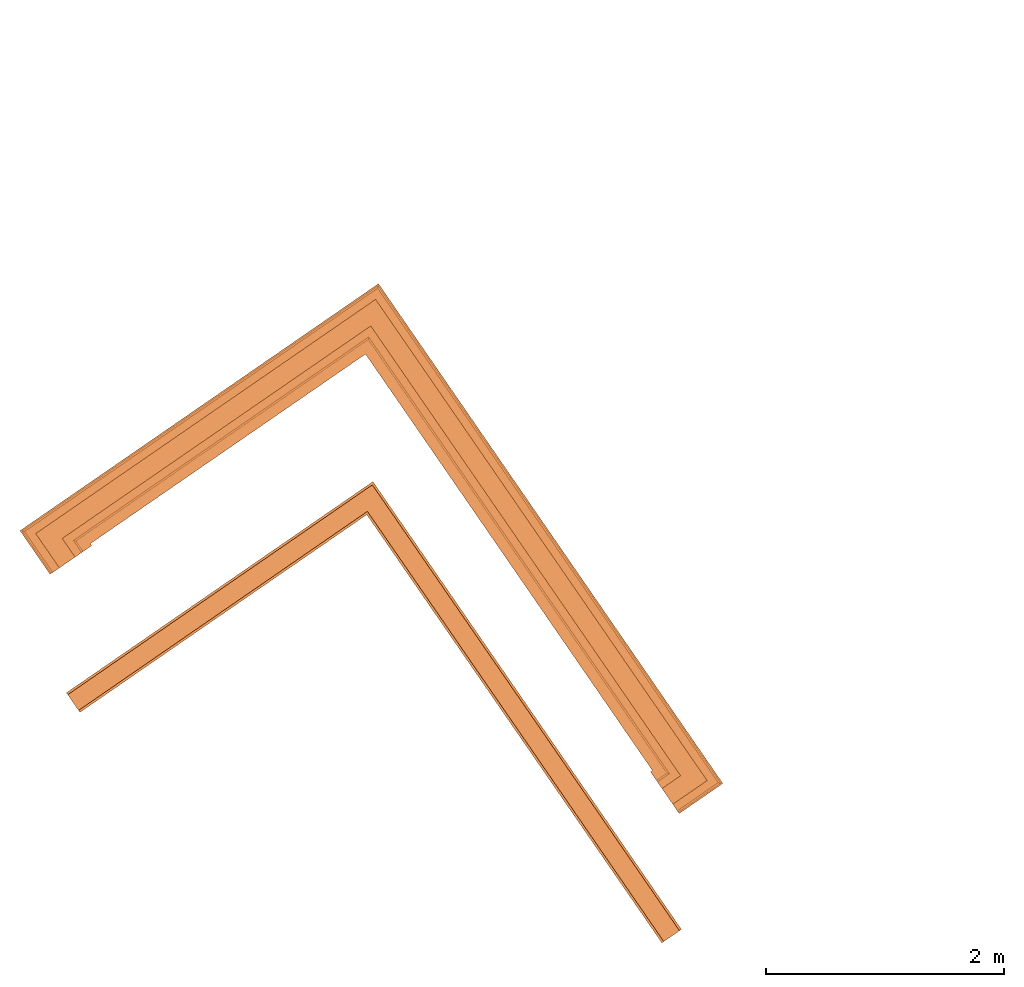
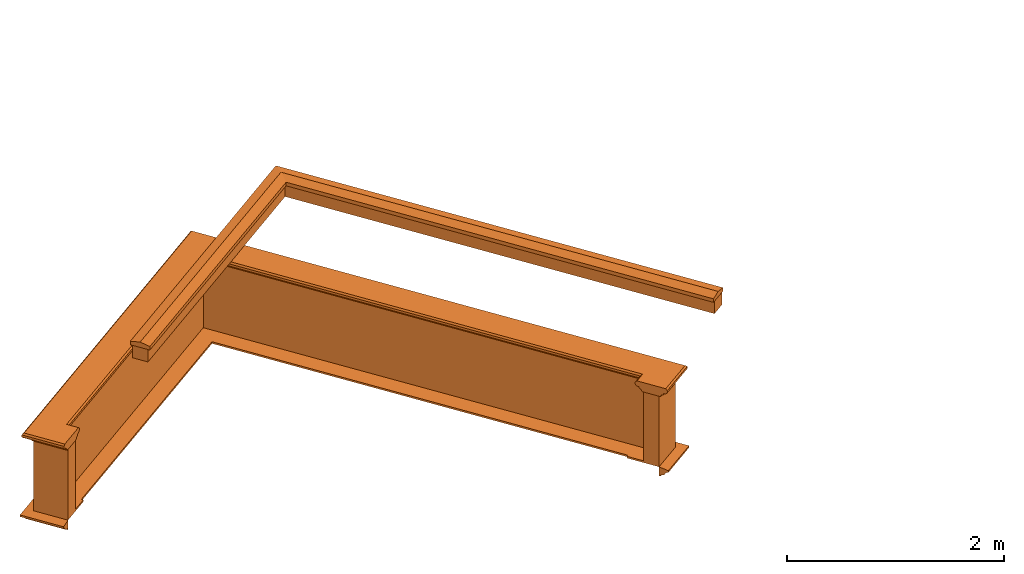
# One storey, part 11 of 12: 5 proxies.
"""IFC2X3 building model written with IfcOpenShell, lengths in metres."""

import ifcopenshell
import ifcopenshell.guid

model = None  # the IFC model being written
_history = None  # IfcOwnerHistory: only IFC2X3 demands one
_inside = {}  # id of a spatial element -> (the spatial element, [elements in it])
_under = {}  # id of a project, library or spatial element -> (it, [spatial elements below it])
_declared = {}  # id of a project -> (the project, [libraries it declares])
_typed = {}  # id of a type object -> (the type object, [elements of that type])
_made_of = {}  # id of a material, layer set ... -> (it, [elements and type objects made of it])


def new_model(schema):
    """Start an empty IFC model of exactly this schema.

    Asked for "IFC4X3", IfcOpenShell would pick the latest addendum, in which some entities
    have other attributes; the version numbers below select the first issue.
    IFC2X3 requires an IfcOwnerHistory on every rooted entity: one is made here for all.
    """
    global model, _history
    if schema == "IFC4X3":
        model = ifcopenshell.file(schema_version=(4, 3, 0, 0))
    else:
        model = ifcopenshell.file(schema=schema)
    _inside.clear()
    _under.clear()
    _declared.clear()
    _typed.clear()
    _made_of.clear()
    _history = None
    if model.schema == "IFC2X3":
        org = make("IfcOrganization", Name="unknown")
        user = make(
            "IfcPersonAndOrganization",
            ThePerson=make("IfcPerson", FamilyName="unknown"),
            TheOrganization=org,
        )
        app = make(
            "IfcApplication",
            ApplicationDeveloper=org,
            Version="unknown",
            ApplicationFullName="unknown",
            ApplicationIdentifier="unknown",
        )
        _history = make(
            "IfcOwnerHistory",
            OwningUser=user,
            OwningApplication=app,
            ChangeAction="ADDED",
            CreationDate=0,
        )
    return model


def make(cls, **values):
    """One entity of the class cls with the attributes given. An attribute that is None is left unset."""
    return model.create_entity(
        cls, **{name: value for name, value in values.items() if value is not None}
    )


def entity(cls, *values):
    """Any entity or typed value of the class cls, its attributes in the order of the schema. None: left unset."""
    e = model.create_entity(cls)
    for i, value in enumerate(values):
        if value is not None:
            e[i] = value
    return e


def rooted(cls, **values):
    """An entity with a GlobalId (a new one), such as an element, a storey or a relation."""
    return make(cls, GlobalId=ifcopenshell.guid.new(), OwnerHistory=_history, **values)


def si_unit(unit_type, name, prefix=None):
    """IfcSIUnit, for example si_unit("LENGTHUNIT", "METRE", prefix="MILLI")."""
    return make("IfcSIUnit", UnitType=unit_type, Prefix=prefix, Name=name)


def assignment(units):
    """IfcUnitAssignment: the units of a project."""
    return None if units is None else make("IfcUnitAssignment", Units=units)


def point(xyz):
    """IfcCartesianPoint."""
    return None if xyz is None else make("IfcCartesianPoint", Coordinates=xyz)


def direction(xyz):
    """IfcDirection."""
    return None if xyz is None else make("IfcDirection", DirectionRatios=xyz)


def frame(location, z_axis=None, x_axis=None):
    """IfcAxis2Placement3D, a coordinate frame: its origin and axes. An axis left out is left unset."""
    return make(
        "IfcAxis2Placement3D",
        Location=point(location),
        Axis=direction(z_axis),
        RefDirection=direction(x_axis),
    )


def origin():
    """The frame at (0, 0, 0) with its axes left unset."""
    return frame((0.0, 0.0, 0.0))


def place(relative_to, where):
    """IfcLocalPlacement: puts the frame where relative to a parent placement (None: the world)."""
    return make(
        "IfcLocalPlacement", PlacementRelTo=relative_to, RelativePlacement=where
    )


def context(
    kind, dimensions, precision=None, world=None, true_north=None, identifier=None
):
    """IfcGeometricRepresentationContext, for example the 3D "Model" context."""
    return make(
        "IfcGeometricRepresentationContext",
        ContextIdentifier=identifier,
        ContextType=kind,
        CoordinateSpaceDimension=dimensions,
        Precision=precision,
        WorldCoordinateSystem=world,
        TrueNorth=true_north,
    )


def subcontext(parent, identifier, kind, view, scale=None):
    """IfcGeometricRepresentationSubContext, for example "Body" below "Model"."""
    return make(
        "IfcGeometricRepresentationSubContext",
        ContextIdentifier=identifier,
        ContextType=kind,
        ParentContext=parent,
        TargetScale=scale,
        TargetView=view,
    )


def project(units=None, contexts=None):
    """IfcProject with its units and contexts."""
    return rooted(
        "IfcProject",
        Name="project",
        RepresentationContexts=contexts,
        UnitsInContext=assignment(units),
    )


def spatial(cls, under=None, at=None, **own):
    """A site, building, storey or space (cls), placed at a placement, below another one or the project."""
    s = rooted(cls, ObjectPlacement=at, **own)
    if under is not None:
        _under.setdefault(under.id(), (under, []))[1].append(s)
    return s


def shape(context_of_items, identifier, shape_type, items):
    """IfcShapeRepresentation: the items that make up one representation, for example the "Body"."""
    return make(
        "IfcShapeRepresentation",
        ContextOfItems=context_of_items,
        RepresentationIdentifier=identifier,
        RepresentationType=shape_type,
        Items=items,
    )


def made_of(thing, what):
    """Note that an element or type object is made of a material, layer set ...; save() writes the relation."""
    if what is not None:
        _made_of.setdefault(what.id(), (what, []))[1].append(thing)
    return thing


def element(
    cls,
    number,
    at=None,
    inside=None,
    cuts=None,
    type_object=None,
    material=None,
    context=None,
    identifier="Body",
    shape_type=None,
    held_by="IfcProductDefinitionShape",
    body=None,
    shapes=None,
    **own,
):
    """One element of the class cls, such as IfcWall. Its Tag is "e" and its number.

    at: its placement. inside: the storey or other place that contains it. cuts: it is an
    opening in that element (IfcRelVoidsElement). A single representation is given by context,
    identifier, shape_type and body (its items); several are given by shapes. held_by: the class
    of the entity that holds the representations. save() writes the other relations.
    """
    e = rooted(cls, Tag="e%d" % number, ObjectPlacement=at, **own)
    if body is not None:
        shapes = [shape(context, identifier, shape_type, body)]
    if shapes is not None:
        e.Representation = make(held_by, Representations=shapes)
    if inside is not None:
        _inside.setdefault(inside.id(), (inside, []))[1].append(e)
    if cuts is not None:
        rooted(
            "IfcRelVoidsElement", RelatingBuildingElement=cuts, RelatedOpeningElement=e
        )
    if type_object is not None:
        _typed.setdefault(type_object.id(), (type_object, []))[1].append(e)
    return made_of(e, material)


def aggregate(whole, parts):
    """IfcRelAggregates: a whole, such as a stair, and the parts it consists of."""
    return rooted("IfcRelAggregates", RelatingObject=whole, RelatedObjects=parts)


def save(model, path):
    """Write the relations noted so far, then the file.

    IfcRelAggregates (storeys below a building ...), IfcRelContainedInSpatialStructure (elements
    in a storey), IfcRelDefinesByType, IfcRelAssociatesMaterial and IfcRelDeclares: one each for
    every whole, place, type object, material and project.
    """
    for whole, parts in _under.values():
        aggregate(whole, parts)
    for where, things in _inside.values():
        rooted(
            "IfcRelContainedInSpatialStructure",
            RelatedElements=things,
            RelatingStructure=where,
        )
    for kind, things in _typed.values():
        rooted("IfcRelDefinesByType", RelatedObjects=things, RelatingType=kind)
    for what, things in _made_of.values():
        rooted("IfcRelAssociatesMaterial", RelatedObjects=things, RelatingMaterial=what)
    for by, libraries in _declared.values():
        rooted("IfcRelDeclares", RelatingContext=by, RelatedDefinitions=libraries)
    model.write(path)


model = new_model("IFC2X3")

# Units and contexts
model_context = context("Model", 3, world=origin())
body_context = subcontext(model_context, "Body", "Model", "MODEL_VIEW")
ifc_project = project(units=[si_unit("PLANEANGLEUNIT", "RADIAN"), si_unit("MASSUNIT", "GRAM", prefix="KILO"), si_unit("FORCEUNIT", "NEWTON", prefix="KILO"), si_unit("LENGTHUNIT", "METRE")], contexts=[model_context])

# Site, building, storey
site_placement = place(None, origin())
site = spatial("IfcSite", under=ifc_project, at=site_placement, CompositionType="ELEMENT")
building_placement = place(None, origin())
building = spatial("IfcBuilding", under=site, at=building_placement, Name="Building plot-7", CompositionType="ELEMENT")
storey_placement = place(None, frame((0.0, 0.0, 8.0)))
storey = spatial("IfcBuildingStorey", under=building, at=storey_placement, Name="Floor 1", CompositionType="ELEMENT", Elevation=8.0)

# Proxies
proxy_1_placement = place(storey_placement, origin())
axis2_placement3_d_1 = entity("IfcAxis2Placement3D", entity("IfcCartesianPoint", [0.0, 0.0, 0.0]))
element("IfcBuildingElementProxy", 1, at=proxy_1_placement, inside=storey, Name="parapet", CompositionType="ELEMENT", context=body_context, shape_type="SweptSolid", held_by="IfcProductRepresentation", body=[
    entity("IfcSurfaceCurveSweptAreaSolid", entity("IfcArbitraryClosedProfileDef", "AREA", None, entity("IfcPolyline", [entity("IfcCartesianPoint", [0.0, 0.25]), entity("IfcCartesianPoint", [0.795, 0.25]), entity("IfcCartesianPoint", [0.795, 0.09]), entity("IfcCartesianPoint", [0.02, 0.09]), entity("IfcCartesianPoint", [0.02, -0.08]), entity("IfcCartesianPoint", [0.0, -0.08]), entity("IfcCartesianPoint", [0.0, 0.25])])), axis2_placement3_d_1, entity("IfcPolyline", [entity("IfcCartesianPoint", [90.5690639482416, 69.7046867128125]), entity("IfcCartesianPoint", [90.6514102150021, 69.7614237584758]), entity("IfcCartesianPoint", [88.1518638427974, 73.3891824818848]), entity("IfcCartesianPoint", [85.7103099814038, 71.706937999249]), entity("IfcCartesianPoint", [85.7670470270672, 71.6245917324885])]), 0.0, 1.0, entity("IfcPlane", axis2_placement3_d_1)),
])
proxy_2_placement = place(storey_placement, origin())
axis2_placement3_d_2 = entity("IfcAxis2Placement3D", entity("IfcCartesianPoint", [0.0, 0.0, 0.0]))
element("IfcBuildingElementProxy", 2, at=proxy_2_placement, inside=storey, Name="parapet", CompositionType="ELEMENT", context=body_context, shape_type="SweptSolid", held_by="IfcProductRepresentation", body=[
    entity("IfcSurfaceCurveSweptAreaSolid", entity("IfcArbitraryClosedProfileDef", "AREA", None, entity("IfcPolyline", [entity("IfcCartesianPoint", [0.795, 0.265]), entity("IfcCartesianPoint", [0.807, 0.268]), entity("IfcCartesianPoint", [0.816, 0.274]), entity("IfcCartesianPoint", [0.822, 0.283]), entity("IfcCartesianPoint", [0.825, 0.295]), entity("IfcCartesianPoint", [0.84, 0.295]), entity("IfcCartesianPoint", [0.84, 0.305]), entity("IfcCartesianPoint", [0.842, 0.317]), entity("IfcCartesianPoint", [0.849, 0.326]), entity("IfcCartesianPoint", [0.858, 0.333]), entity("IfcCartesianPoint", [0.87, 0.335]), entity("IfcCartesianPoint", [0.882, 0.333]), entity("IfcCartesianPoint", [0.891, 0.326]), entity("IfcCartesianPoint", [0.898, 0.317]), entity("IfcCartesianPoint", [0.9, 0.305]), entity("IfcCartesianPoint", [0.9, 0.035]), entity("IfcCartesianPoint", [0.898, 0.023]), entity("IfcCartesianPoint", [0.891, 0.014]), entity("IfcCartesianPoint", [0.882, 0.007]), entity("IfcCartesianPoint", [0.87, 0.005]), entity("IfcCartesianPoint", [0.858, 0.007]), entity("IfcCartesianPoint", [0.849, 0.014]), entity("IfcCartesianPoint", [0.842, 0.023]), entity("IfcCartesianPoint", [0.84, 0.035]), entity("IfcCartesianPoint", [0.84, 0.045]), entity("IfcCartesianPoint", [0.825, 0.045]), entity("IfcCartesianPoint", [0.822, 0.057]), entity("IfcCartesianPoint", [0.816, 0.066]), entity("IfcCartesianPoint", [0.807, 0.072]), entity("IfcCartesianPoint", [0.795, 0.075]), entity("IfcCartesianPoint", [0.795, 0.265])])), axis2_placement3_d_2, entity("IfcPolyline", [entity("IfcCartesianPoint", [90.5690639482416, 69.7046867128125]), entity("IfcCartesianPoint", [90.6514102150021, 69.7614237584758]), entity("IfcCartesianPoint", [88.1518638427974, 73.3891824818848]), entity("IfcCartesianPoint", [85.7103099814038, 71.706937999249]), entity("IfcCartesianPoint", [85.7670470270672, 71.6245917324885])]), 0.0, 1.0, entity("IfcPlane", axis2_placement3_d_2)),
])
proxy_3_placement = place(storey_placement, origin())
axis2_placement3_d_3 = entity("IfcAxis2Placement3D", entity("IfcCartesianPoint", [0.0, 0.0, 0.0]))
element("IfcBuildingElementProxy", 3, at=proxy_3_placement, inside=storey, Name="parapet", CompositionType="ELEMENT", context=body_context, shape_type="SweptSolid", held_by="IfcProductRepresentation", body=[
    entity("IfcSurfaceCurveSweptAreaSolid", entity("IfcArbitraryClosedProfileDef", "AREA", None, entity("IfcPolyline", [entity("IfcCartesianPoint", [-0.1, 0.25]), entity("IfcCartesianPoint", [-0.1, 0.265]), entity("IfcCartesianPoint", [-0.085, 0.265]), entity("IfcCartesianPoint", [-0.084, 0.278]), entity("IfcCartesianPoint", [-0.081, 0.289]), entity("IfcCartesianPoint", [-0.074, 0.301]), entity("IfcCartesianPoint", [-0.065, 0.309]), entity("IfcCartesianPoint", [-0.055, 0.315]), entity("IfcCartesianPoint", [-0.044, 0.324]), entity("IfcCartesianPoint", [-0.038, 0.334]), entity("IfcCartesianPoint", [-0.035, 0.345]), entity("IfcCartesianPoint", [-0.015, 0.345]), entity("IfcCartesianPoint", [0.0, 0.25]), entity("IfcCartesianPoint", [-0.1, 0.25])])), axis2_placement3_d_3, entity("IfcPolyline", [entity("IfcCartesianPoint", [90.5690639482416, 69.7046867128125]), entity("IfcCartesianPoint", [90.6514102150021, 69.7614237584758]), entity("IfcCartesianPoint", [88.1518638427974, 73.3891824818848]), entity("IfcCartesianPoint", [85.7103099814038, 71.706937999249]), entity("IfcCartesianPoint", [85.7670470270672, 71.6245917324885])]), 0.0, 1.0, entity("IfcPlane", axis2_placement3_d_3)),
])
proxy_4_placement = place(storey_placement, frame((0.0, 0.0, 3.15)))
axis2_placement3_d_4 = entity("IfcAxis2Placement3D", entity("IfcCartesianPoint", [0.0, 0.0, 0.0]))
element("IfcBuildingElementProxy", 4, at=proxy_4_placement, inside=storey, Name="pergola beam", CompositionType="ELEMENT", context=body_context, shape_type="SweptSolid", held_by="IfcProductRepresentation", body=[
    entity("IfcSurfaceCurveSweptAreaSolid", entity("IfcArbitraryClosedProfileDef", "AREA", None, entity("IfcPolyline", [entity("IfcCartesianPoint", [-0.7, -0.08]), entity("IfcCartesianPoint", [-0.7, 0.08]), entity("IfcCartesianPoint", [-0.56, 0.08]), entity("IfcCartesianPoint", [-0.56, -0.08]), entity("IfcCartesianPoint", [-0.7, -0.08])])), axis2_placement3_d_4, entity("IfcPolyline", [entity("IfcCartesianPoint", [90.6854524424001, 69.7120159984195]), entity("IfcCartesianPoint", [88.1518638427974, 73.3891824818848]), entity("IfcCartesianPoint", [85.6609022213475, 71.672895771851])]), 0.0, 1.0, entity("IfcPlane", axis2_placement3_d_4)),
])
proxy_5_placement = place(storey_placement, frame((0.0, 0.0, 3.15)))
axis2_placement3_d_5 = entity("IfcAxis2Placement3D", entity("IfcCartesianPoint", [0.0, 0.0, 0.0]))
element("IfcBuildingElementProxy", 5, at=proxy_5_placement, inside=storey, Name="pergola beam", CompositionType="ELEMENT", context=body_context, shape_type="SweptSolid", held_by="IfcProductRepresentation", body=[
    entity("IfcSurfaceCurveSweptAreaSolid", entity("IfcArbitraryClosedProfileDef", "AREA", None, entity("IfcPolyline", [entity("IfcCartesianPoint", [-0.5, 0.0]), entity("IfcCartesianPoint", [-0.52, -0.1]), entity("IfcCartesianPoint", [-0.56, -0.1]), entity("IfcCartesianPoint", [-0.56, 0.1]), entity("IfcCartesianPoint", [-0.52, 0.1]), entity("IfcCartesianPoint", [-0.5, 0.0])])), axis2_placement3_d_5, entity("IfcPolyline", [entity("IfcCartesianPoint", [90.6854524424001, 69.7120159984195]), entity("IfcCartesianPoint", [88.1518638427974, 73.3891824818848]), entity("IfcCartesianPoint", [85.6609022213475, 71.672895771851])]), 0.0, 1.0, entity("IfcPlane", axis2_placement3_d_5)),
])

save(model, "model.ifc")
